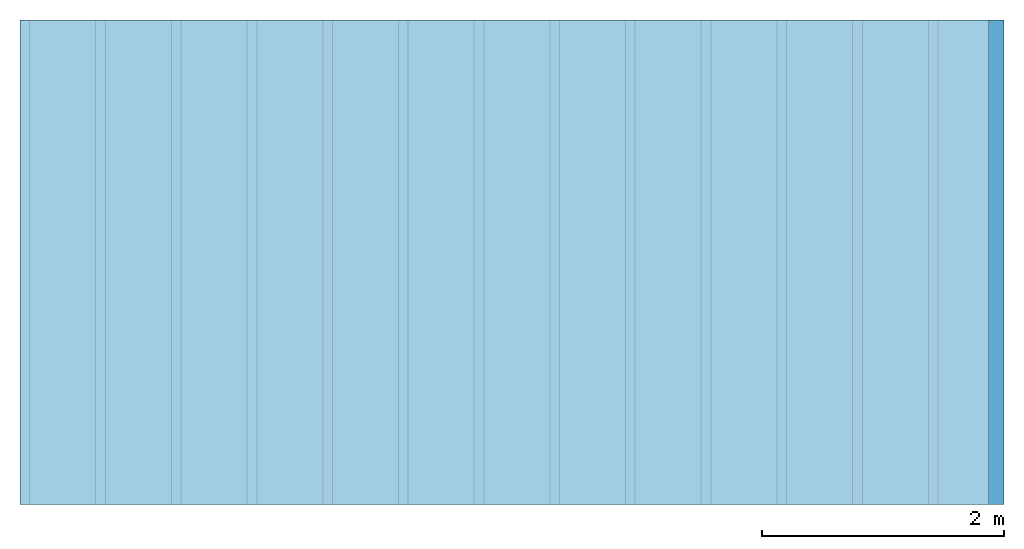
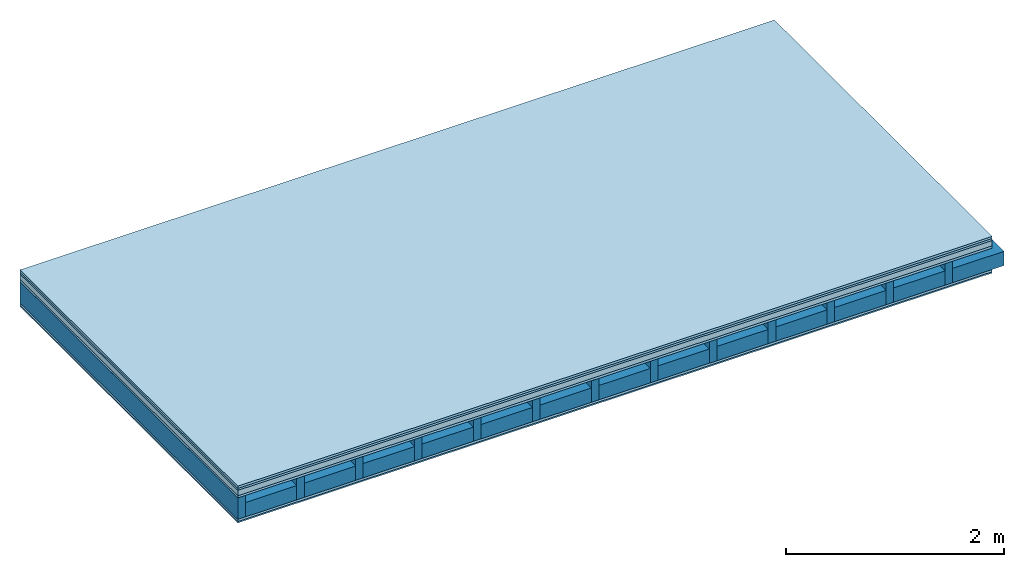
# One storey: 6 plates, 2 members, 1 element without a shape of its own.
"""IFC4 building model written with IfcOpenShell, lengths in metres."""

from ifc_helpers import new_model, si_unit, derived_unit, direction, frame, frame_2d, origin, origin_with_axes, place, context, project, spatial, rectangle, extrude, material, layer, layer_set, type_object, element, aggregate, save


model = new_model("IFC4")

# Units and contexts
plan_context = context("Plan", 3, precision=1e-05, world=origin(), true_north=direction((0.0, 1.0)))
model_context = context("Model", 3, precision=1e-05, world=origin(), true_north=direction((0.0, 1.0)))
ifc_project = project(units=[si_unit("LENGTHUNIT", "METRE"), derived_unit("SOUNDPRESSUREUNIT", [(si_unit("PRESSUREUNIT", "PASCAL", prefix="MICRO"), 0)]), si_unit("ENERGYUNIT", "JOULE", prefix="MEGA"), si_unit("MASSUNIT", "GRAM", prefix="KILO"), derived_unit("THERMALTRANSMITTANCEUNIT", [(si_unit("POWERUNIT", "WATT"), 1), (si_unit("AREAUNIT", "SQUARE_METRE"), -1), (si_unit("THERMODYNAMICTEMPERATUREUNIT", "KELVIN"), -1)]), derived_unit("AREADENSITYUNIT", [(si_unit("MASSUNIT", "GRAM", prefix="KILO"), 1), (si_unit("AREAUNIT", "SQUARE_METRE"), -1)]), derived_unit("USERDEFINED", [(si_unit("ENERGYUNIT", "JOULE", prefix="MEGA"), 1), (si_unit("AREAUNIT", "SQUARE_METRE"), -1)])], contexts=[plan_context, model_context])

# Site, building, storey
site = spatial("IfcSite", under=ifc_project)
building_placement = place(None, origin())
building = spatial("IfcBuilding", under=site, at=building_placement)
storey_placement = place(building_placement, origin())
storey = spatial("IfcBuildingStorey", under=building, at=storey_placement)

# Slab, members, plates
ifc_material_1 = material(Name="Floor heating system Therm38 longitudinal", Category="03.007")
ifc_layer_1 = layer(ifc_material_1, 0.025, Name="On-material")
ifc_material_2 = material(Category="10.009")
ifc_layer_2 = layer(ifc_material_2, 0.022, Name="Impact sound insulation")
ifc_material_3 = material(Name="Cement panels, glued on sub-floor", Category="02.007")
ifc_layer_3 = layer(ifc_material_3, 0.06, Name="on Supporting structure")
ifc_material_4 = material(Category="07.001")
ifc_layer_4 = layer(ifc_material_4, 0.025, Name="Sub-floor")
ifc_material_5 = material(Name="Rigid, of the art")
ifc_layer_5 = layer(ifc_material_5, 0.0, Name="Bond")
ifc_layer_6 = layer(None, 0.24, Name="Supporting structure")
ifc_layer_7 = layer(ifc_material_5, 0.0, Name="Bond")
ifc_layer_8 = layer(ifc_material_4, 0.025, Name="Lower layer 1")
ifc_material_6 = material(Category="03.007")
ifc_layer_9 = layer(ifc_material_6, 0.015, Name="Lower 2nd layer")
ifc_layer_set = layer_set([ifc_layer_1, ifc_layer_2, ifc_layer_3, ifc_layer_4, ifc_layer_5, ifc_layer_6, ifc_layer_7, ifc_layer_8, ifc_layer_9])
slab_type = type_object("IfcSlabType", Name="A0435", PredefinedType="NOTDEFINED", material=ifc_layer_set)
slab_placement = place(None, frame((0.0, 0.0, 0.0), z_axis=(0.0, 0.0, -1.0), x_axis=(1.0, 0.0, 0.0)))
slab = element("IfcSlab", 1, at=slab_placement, inside=storey, type_object=slab_type, material=ifc_layer_set, Name="Slab #1")
ifc_material_7 = material()
member_1_placement = place(slab_placement, origin())
member_1 = element("IfcMember", 2, at=member_1_placement, material=ifc_material_7, Name="Supporting structure", context=plan_context, shape_type="SweptSolid", body=[
    extrude(rectangle(XDim=0.08, YDim=0.24, at=frame_2d((0.04, 0.12), x_axis=(1.0, 0.0))), frame((0.0, 4.0, 0.132), z_axis=(0.0, -1.0, 0.0), x_axis=(1.0, 0.0, 0.0)), (0.0, 0.0, 1.0), 4.0),
    extrude(rectangle(XDim=0.08, YDim=0.24, at=frame_2d((0.04, 0.12), x_axis=(1.0, 0.0))), frame((0.625, 4.0, 0.132), z_axis=(0.0, -1.0, 0.0), x_axis=(1.0, 0.0, 0.0)), (0.0, 0.0, 1.0), 4.0),
    extrude(rectangle(XDim=0.08, YDim=0.24, at=frame_2d((0.04, 0.12), x_axis=(1.0, 0.0))), frame((1.25, 4.0, 0.132), z_axis=(0.0, -1.0, 0.0), x_axis=(1.0, 0.0, 0.0)), (0.0, 0.0, 1.0), 4.0),
    extrude(rectangle(XDim=0.08, YDim=0.24, at=frame_2d((0.04, 0.12), x_axis=(1.0, 0.0))), frame((1.875, 4.0, 0.132), z_axis=(0.0, -1.0, 0.0), x_axis=(1.0, 0.0, 0.0)), (0.0, 0.0, 1.0), 4.0),
    extrude(rectangle(XDim=0.08, YDim=0.24, at=frame_2d((0.04, 0.12), x_axis=(1.0, 0.0))), frame((2.5, 4.0, 0.132), z_axis=(0.0, -1.0, 0.0), x_axis=(1.0, 0.0, 0.0)), (0.0, 0.0, 1.0), 4.0),
    extrude(rectangle(XDim=0.08, YDim=0.24, at=frame_2d((0.04, 0.12), x_axis=(1.0, 0.0))), frame((3.125, 4.0, 0.132), z_axis=(0.0, -1.0, 0.0), x_axis=(1.0, 0.0, 0.0)), (0.0, 0.0, 1.0), 4.0),
    extrude(rectangle(XDim=0.08, YDim=0.24, at=frame_2d((0.04, 0.12), x_axis=(1.0, 0.0))), frame((3.75, 4.0, 0.132), z_axis=(0.0, -1.0, 0.0), x_axis=(1.0, 0.0, 0.0)), (0.0, 0.0, 1.0), 4.0),
    extrude(rectangle(XDim=0.08, YDim=0.24, at=frame_2d((0.04, 0.12), x_axis=(1.0, 0.0))), frame((4.375, 4.0, 0.132), z_axis=(0.0, -1.0, 0.0), x_axis=(1.0, 0.0, 0.0)), (0.0, 0.0, 1.0), 4.0),
    extrude(rectangle(XDim=0.08, YDim=0.24, at=frame_2d((0.04, 0.12), x_axis=(1.0, 0.0))), frame((5.0, 4.0, 0.132), z_axis=(0.0, -1.0, 0.0), x_axis=(1.0, 0.0, 0.0)), (0.0, 0.0, 1.0), 4.0),
    extrude(rectangle(XDim=0.08, YDim=0.24, at=frame_2d((0.04, 0.12), x_axis=(1.0, 0.0))), frame((5.625, 4.0, 0.132), z_axis=(0.0, -1.0, 0.0), x_axis=(1.0, 0.0, 0.0)), (0.0, 0.0, 1.0), 4.0),
    extrude(rectangle(XDim=0.08, YDim=0.24, at=frame_2d((0.04, 0.12), x_axis=(1.0, 0.0))), frame((6.25, 4.0, 0.132), z_axis=(0.0, -1.0, 0.0), x_axis=(1.0, 0.0, 0.0)), (0.0, 0.0, 1.0), 4.0),
    extrude(rectangle(XDim=0.08, YDim=0.24, at=frame_2d((0.04, 0.12), x_axis=(1.0, 0.0))), frame((6.875, 4.0, 0.132), z_axis=(0.0, -1.0, 0.0), x_axis=(1.0, 0.0, 0.0)), (0.0, 0.0, 1.0), 4.0),
    extrude(rectangle(XDim=0.08, YDim=0.24, at=frame_2d((0.04, 0.12), x_axis=(1.0, 0.0))), frame((7.5, 4.0, 0.132), z_axis=(0.0, -1.0, 0.0), x_axis=(1.0, 0.0, 0.0)), (0.0, 0.0, 1.0), 4.0),
])
ifc_material_8 = material()
member_2_placement = place(slab_placement, origin())
member_2 = element("IfcMember", 3, at=member_2_placement, material=ifc_material_8, Name="Cavity", context=plan_context, shape_type="SweptSolid", body=[
    extrude(rectangle(XDim=0.545, YDim=0.16, at=frame_2d((0.2725, 0.08), x_axis=(1.0, 0.0))), frame((0.08, 4.0, 0.212), z_axis=(0.0, -1.0, 0.0), x_axis=(1.0, 0.0, 0.0)), (0.0, 0.0, 1.0), 4.0),
    extrude(rectangle(XDim=0.545, YDim=0.16, at=frame_2d((0.2725, 0.08), x_axis=(1.0, 0.0))), frame((0.705, 4.0, 0.212), z_axis=(0.0, -1.0, 0.0), x_axis=(1.0, 0.0, 0.0)), (0.0, 0.0, 1.0), 4.0),
    extrude(rectangle(XDim=0.545, YDim=0.16, at=frame_2d((0.2725, 0.08), x_axis=(1.0, 0.0))), frame((1.33, 4.0, 0.212), z_axis=(0.0, -1.0, 0.0), x_axis=(1.0, 0.0, 0.0)), (0.0, 0.0, 1.0), 4.0),
    extrude(rectangle(XDim=0.545, YDim=0.16, at=frame_2d((0.2725, 0.08), x_axis=(1.0, 0.0))), frame((1.955, 4.0, 0.212), z_axis=(0.0, -1.0, 0.0), x_axis=(1.0, 0.0, 0.0)), (0.0, 0.0, 1.0), 4.0),
    extrude(rectangle(XDim=0.545, YDim=0.16, at=frame_2d((0.2725, 0.08), x_axis=(1.0, 0.0))), frame((2.58, 4.0, 0.212), z_axis=(0.0, -1.0, 0.0), x_axis=(1.0, 0.0, 0.0)), (0.0, 0.0, 1.0), 4.0),
    extrude(rectangle(XDim=0.545, YDim=0.16, at=frame_2d((0.2725, 0.08), x_axis=(1.0, 0.0))), frame((3.205, 4.0, 0.212), z_axis=(0.0, -1.0, 0.0), x_axis=(1.0, 0.0, 0.0)), (0.0, 0.0, 1.0), 4.0),
    extrude(rectangle(XDim=0.545, YDim=0.16, at=frame_2d((0.2725, 0.08), x_axis=(1.0, 0.0))), frame((3.83, 4.0, 0.212), z_axis=(0.0, -1.0, 0.0), x_axis=(1.0, 0.0, 0.0)), (0.0, 0.0, 1.0), 4.0),
    extrude(rectangle(XDim=0.545, YDim=0.16, at=frame_2d((0.2725, 0.08), x_axis=(1.0, 0.0))), frame((4.455, 4.0, 0.212), z_axis=(0.0, -1.0, 0.0), x_axis=(1.0, 0.0, 0.0)), (0.0, 0.0, 1.0), 4.0),
    extrude(rectangle(XDim=0.545, YDim=0.16, at=frame_2d((0.2725, 0.08), x_axis=(1.0, 0.0))), frame((5.08, 4.0, 0.212), z_axis=(0.0, -1.0, 0.0), x_axis=(1.0, 0.0, 0.0)), (0.0, 0.0, 1.0), 4.0),
    extrude(rectangle(XDim=0.545, YDim=0.16, at=frame_2d((0.2725, 0.08), x_axis=(1.0, 0.0))), frame((5.705, 4.0, 0.212), z_axis=(0.0, -1.0, 0.0), x_axis=(1.0, 0.0, 0.0)), (0.0, 0.0, 1.0), 4.0),
    extrude(rectangle(XDim=0.545, YDim=0.16, at=frame_2d((0.2725, 0.08), x_axis=(1.0, 0.0))), frame((6.33, 4.0, 0.212), z_axis=(0.0, -1.0, 0.0), x_axis=(1.0, 0.0, 0.0)), (0.0, 0.0, 1.0), 4.0),
    extrude(rectangle(XDim=0.545, YDim=0.16, at=frame_2d((0.2725, 0.08), x_axis=(1.0, 0.0))), frame((6.955, 4.0, 0.212), z_axis=(0.0, -1.0, 0.0), x_axis=(1.0, 0.0, 0.0)), (0.0, 0.0, 1.0), 4.0),
    extrude(rectangle(XDim=0.545, YDim=0.16, at=frame_2d((0.2725, 0.08), x_axis=(1.0, 0.0))), frame((7.58, 4.0, 0.212), z_axis=(0.0, -1.0, 0.0), x_axis=(1.0, 0.0, 0.0)), (0.0, 0.0, 1.0), 4.0),
])
plate_1_placement = place(slab_placement, origin())
plate_1 = element("IfcPlate", 4, at=plate_1_placement, material=ifc_material_1, Name="On-material", context=plan_context, shape_type="SweptSolid", body=[
    extrude(rectangle(XDim=8.0, YDim=4.0, at=frame_2d((4.0, 2.0), x_axis=(1.0, 0.0))), origin_with_axes(), (0.0, 0.0, 1.0), 0.025),
])
plate_2_placement = place(slab_placement, origin())
plate_2 = element("IfcPlate", 5, at=plate_2_placement, material=ifc_material_2, Name="Impact sound insulation", context=plan_context, shape_type="SweptSolid", body=[
    extrude(rectangle(XDim=8.0, YDim=4.0, at=frame_2d((4.0, 2.0), x_axis=(1.0, 0.0))), frame((0.0, 0.0, 0.025), z_axis=(0.0, 0.0, 1.0), x_axis=(1.0, 0.0, 0.0)), (0.0, 0.0, 1.0), 0.022),
])
plate_3_placement = place(slab_placement, origin())
plate_3 = element("IfcPlate", 6, at=plate_3_placement, material=ifc_material_3, Name="on Supporting structure", context=plan_context, shape_type="SweptSolid", body=[
    extrude(rectangle(XDim=8.0, YDim=4.0, at=frame_2d((4.0, 2.0), x_axis=(1.0, 0.0))), frame((0.0, 0.0, 0.047), z_axis=(0.0, 0.0, 1.0), x_axis=(1.0, 0.0, 0.0)), (0.0, 0.0, 1.0), 0.06),
])
plate_4_placement = place(slab_placement, origin())
plate_4 = element("IfcPlate", 7, at=plate_4_placement, material=ifc_material_4, Name="Sub-floor", context=plan_context, shape_type="SweptSolid", body=[
    extrude(rectangle(XDim=8.0, YDim=4.0, at=frame_2d((4.0, 2.0), x_axis=(1.0, 0.0))), frame((0.0, 0.0, 0.107), z_axis=(0.0, 0.0, 1.0), x_axis=(1.0, 0.0, 0.0)), (0.0, 0.0, 1.0), 0.025),
])
plate_5_placement = place(slab_placement, origin())
plate_5 = element("IfcPlate", 8, at=plate_5_placement, material=ifc_material_4, Name="Lower layer 1", context=plan_context, shape_type="SweptSolid", body=[
    extrude(rectangle(XDim=8.0, YDim=4.0, at=frame_2d((4.0, 2.0), x_axis=(1.0, 0.0))), frame((0.0, 0.0, 0.372), z_axis=(0.0, 0.0, 1.0), x_axis=(1.0, 0.0, 0.0)), (0.0, 0.0, 1.0), 0.025),
])
plate_6_placement = place(slab_placement, origin())
plate_6 = element("IfcPlate", 9, at=plate_6_placement, material=ifc_material_6, Name="Lower 2nd layer", context=plan_context, shape_type="SweptSolid", body=[
    extrude(rectangle(XDim=8.0, YDim=4.0, at=frame_2d((4.0, 2.0), x_axis=(1.0, 0.0))), frame((0.0, 0.0, 0.397), z_axis=(0.0, 0.0, 1.0), x_axis=(1.0, 0.0, 0.0)), (0.0, 0.0, 1.0), 0.015),
])
aggregate(slab, [plate_1, plate_2, plate_3, plate_4, member_1, member_2, plate_5, plate_6])

save(model, "model.ifc")
